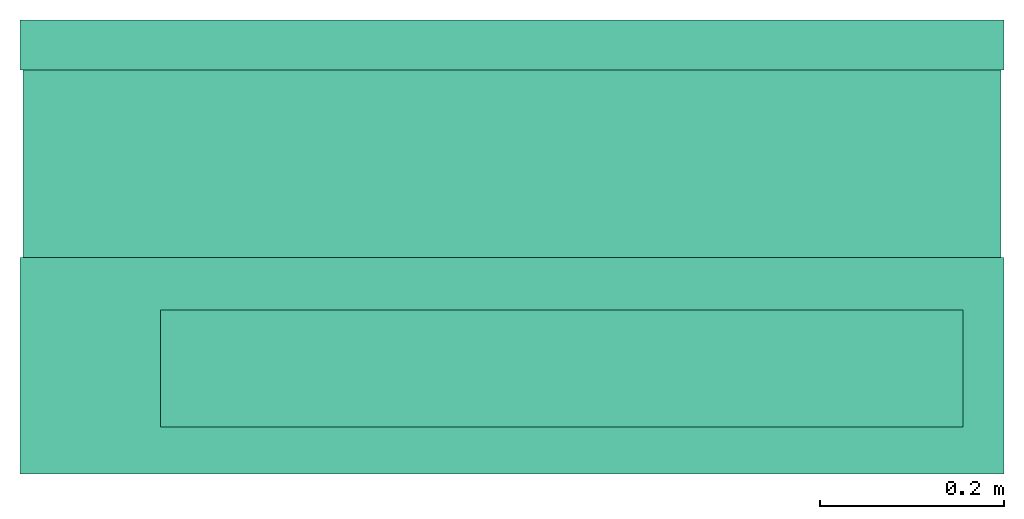
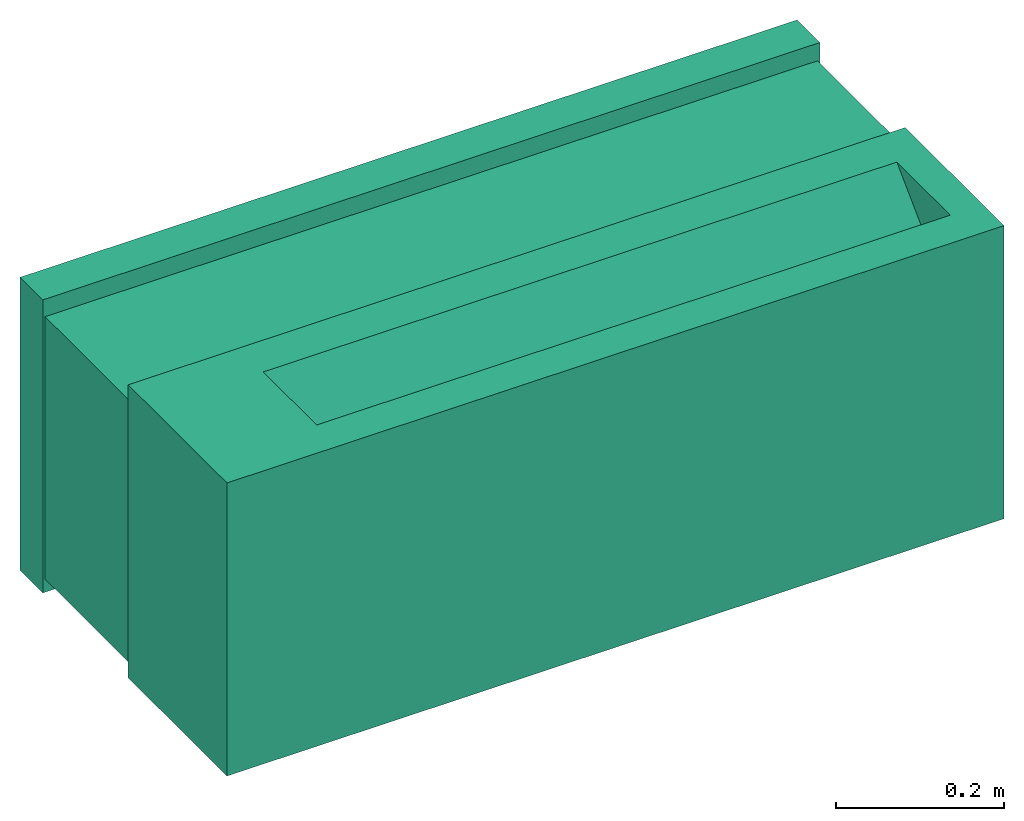
# One storey: 1 energy conversion device.
"""IFC2X3 building model written with IfcOpenShell, lengths in metres."""

import ifcopenshell
import ifcopenshell.guid

model = None  # the IFC model being written
_history = None  # IfcOwnerHistory: only IFC2X3 demands one
_inside = {}  # id of a spatial element -> (the spatial element, [elements in it])
_under = {}  # id of a project, library or spatial element -> (it, [spatial elements below it])
_declared = {}  # id of a project -> (the project, [libraries it declares])
_typed = {}  # id of a type object -> (the type object, [elements of that type])
_made_of = {}  # id of a material, layer set ... -> (it, [elements and type objects made of it])


def new_model(schema):
    """Start an empty IFC model of exactly this schema.

    Asked for "IFC4X3", IfcOpenShell would pick the latest addendum, in which some entities
    have other attributes; the version numbers below select the first issue.
    IFC2X3 requires an IfcOwnerHistory on every rooted entity: one is made here for all.
    """
    global model, _history
    if schema == "IFC4X3":
        model = ifcopenshell.file(schema_version=(4, 3, 0, 0))
    else:
        model = ifcopenshell.file(schema=schema)
    _inside.clear()
    _under.clear()
    _declared.clear()
    _typed.clear()
    _made_of.clear()
    _history = None
    if model.schema == "IFC2X3":
        org = make("IfcOrganization", Name="unknown")
        user = make(
            "IfcPersonAndOrganization",
            ThePerson=make("IfcPerson", FamilyName="unknown"),
            TheOrganization=org,
        )
        app = make(
            "IfcApplication",
            ApplicationDeveloper=org,
            Version="unknown",
            ApplicationFullName="unknown",
            ApplicationIdentifier="unknown",
        )
        _history = make(
            "IfcOwnerHistory",
            OwningUser=user,
            OwningApplication=app,
            ChangeAction="ADDED",
            CreationDate=0,
        )
    return model


def make(cls, **values):
    """One entity of the class cls with the attributes given. An attribute that is None is left unset."""
    return model.create_entity(
        cls, **{name: value for name, value in values.items() if value is not None}
    )


def entity(cls, *values):
    """Any entity or typed value of the class cls, its attributes in the order of the schema. None: left unset."""
    e = model.create_entity(cls)
    for i, value in enumerate(values):
        if value is not None:
            e[i] = value
    return e


def rooted(cls, **values):
    """An entity with a GlobalId (a new one), such as an element, a storey or a relation."""
    return make(cls, GlobalId=ifcopenshell.guid.new(), OwnerHistory=_history, **values)


def si_unit(unit_type, name, prefix=None):
    """IfcSIUnit, for example si_unit("LENGTHUNIT", "METRE", prefix="MILLI")."""
    return make("IfcSIUnit", UnitType=unit_type, Prefix=prefix, Name=name)


def converted_unit(unit_type, name, factor, base, dimensions=None, offset=None):
    """IfcConversionBasedUnit, such as the inch: factor (a typed value) times the base unit."""
    return make(
        "IfcConversionBasedUnit"
        if offset is None
        else "IfcConversionBasedUnitWithOffset",
        ConversionOffset=offset,
        Dimensions=None
        if dimensions is None
        else entity("IfcDimensionalExponents", *dimensions),
        UnitType=unit_type,
        Name=name,
        ConversionFactor=make(
            "IfcMeasureWithUnit", ValueComponent=factor, UnitComponent=base
        ),
    )


def assignment(units):
    """IfcUnitAssignment: the units of a project."""
    return None if units is None else make("IfcUnitAssignment", Units=units)


def point(xyz):
    """IfcCartesianPoint."""
    return None if xyz is None else make("IfcCartesianPoint", Coordinates=xyz)


def direction(xyz):
    """IfcDirection."""
    return None if xyz is None else make("IfcDirection", DirectionRatios=xyz)


def frame(location, z_axis=None, x_axis=None):
    """IfcAxis2Placement3D, a coordinate frame: its origin and axes. An axis left out is left unset."""
    return make(
        "IfcAxis2Placement3D",
        Location=point(location),
        Axis=direction(z_axis),
        RefDirection=direction(x_axis),
    )


def origin():
    """The frame at (0, 0, 0) with its axes left unset."""
    return frame((0.0, 0.0, 0.0))


def origin_with_axes():
    """The frame at (0, 0, 0) with the z axis (0, 0, 1) and the x axis (1, 0, 0) written out."""
    return frame((0.0, 0.0, 0.0), z_axis=(0.0, 0.0, 1.0), x_axis=(1.0, 0.0, 0.0))


def place(relative_to, where):
    """IfcLocalPlacement: puts the frame where relative to a parent placement (None: the world)."""
    return make(
        "IfcLocalPlacement", PlacementRelTo=relative_to, RelativePlacement=where
    )


def context(
    kind, dimensions, precision=None, world=None, true_north=None, identifier=None
):
    """IfcGeometricRepresentationContext, for example the 3D "Model" context."""
    return make(
        "IfcGeometricRepresentationContext",
        ContextIdentifier=identifier,
        ContextType=kind,
        CoordinateSpaceDimension=dimensions,
        Precision=precision,
        WorldCoordinateSystem=world,
        TrueNorth=true_north,
    )


def subcontext(parent, identifier, kind, view, scale=None):
    """IfcGeometricRepresentationSubContext, for example "Body" below "Model"."""
    return make(
        "IfcGeometricRepresentationSubContext",
        ContextIdentifier=identifier,
        ContextType=kind,
        ParentContext=parent,
        TargetScale=scale,
        TargetView=view,
    )


def project(units=None, contexts=None):
    """IfcProject with its units and contexts."""
    return rooted(
        "IfcProject",
        Name="project",
        RepresentationContexts=contexts,
        UnitsInContext=assignment(units),
    )


def spatial(cls, under=None, at=None, **own):
    """A site, building, storey or space (cls), placed at a placement, below another one or the project."""
    s = rooted(cls, ObjectPlacement=at, **own)
    if under is not None:
        _under.setdefault(under.id(), (under, []))[1].append(s)
    return s


def faces_of(points, faces, orient=None, outer=None):
    """IfcFace entities. A face is a list of loops; a loop is a list of indices into points, from 0.

    orient and outer hold one flag for each loop. By default every Orientation is true, the
    first loop of a face is its IfcFaceOuterBound and the others are IfcFaceBound.
    """
    made = []
    for i, loops in enumerate(faces):
        bounds = []
        for j, loop in enumerate(loops):
            is_outer = j == 0 if outer is None else outer[i][j]
            bounds.append(
                make(
                    "IfcFaceOuterBound" if is_outer else "IfcFaceBound",
                    Bound=make("IfcPolyLoop", Polygon=[points[k] for k in loop]),
                    Orientation=True if orient is None else orient[i][j],
                )
            )
        made.append(make("IfcFace", Bounds=bounds))
    return made


def open_shell(faces, orient=None, outer=None):
    """The faces of one IfcOpenShell. surface_model builds it on its shared points."""
    return ("IfcOpenShell", faces, orient, outer)


def faceted_brep(points, faces, orient=None, outer=None, voids=None):
    """IfcFacetedBrep: a solid bounded by flat faces; with voids (closed shells), ...WithVoids."""
    shared = [point(p) for p in points]
    hull = make("IfcClosedShell", CfsFaces=faces_of(shared, faces, orient, outer))
    if voids is None:
        return make("IfcFacetedBrep", Outer=hull)
    return make(
        "IfcFacetedBrepWithVoids",
        Outer=hull,
        Voids=[
            make(cls, CfsFaces=faces_of(shared, fs, o, b)) for cls, fs, o, b in voids
        ],
    )


def surface_model(cls, points, shells):
    """IfcFaceBasedSurfaceModel or IfcShellBasedSurfaceModel (cls): surfaces that need not close."""
    shared = [point(p) for p in points]
    made = [make(c, CfsFaces=faces_of(shared, fs, o, b)) for c, fs, o, b in shells]
    if cls == "IfcFaceBasedSurfaceModel":
        return make(cls, FbsmFaces=made)
    return make(cls, SbsmBoundary=made)


def shape(context_of_items, identifier, shape_type, items):
    """IfcShapeRepresentation: the items that make up one representation, for example the "Body"."""
    return make(
        "IfcShapeRepresentation",
        ContextOfItems=context_of_items,
        RepresentationIdentifier=identifier,
        RepresentationType=shape_type,
        Items=items,
    )


def made_of(thing, what):
    """Note that an element or type object is made of a material, layer set ...; save() writes the relation."""
    if what is not None:
        _made_of.setdefault(what.id(), (what, []))[1].append(thing)
    return thing


def type_object(cls, material=None, **own):
    """A type object (cls), such as IfcWallType, which elements share."""
    return made_of(rooted(cls, **own), material)


def element(
    cls,
    number,
    at=None,
    inside=None,
    cuts=None,
    type_object=None,
    material=None,
    context=None,
    identifier="Body",
    shape_type=None,
    held_by="IfcProductDefinitionShape",
    body=None,
    shapes=None,
    **own,
):
    """One element of the class cls, such as IfcWall. Its Tag is "e" and its number.

    at: its placement. inside: the storey or other place that contains it. cuts: it is an
    opening in that element (IfcRelVoidsElement). A single representation is given by context,
    identifier, shape_type and body (its items); several are given by shapes. held_by: the class
    of the entity that holds the representations. save() writes the other relations.
    """
    e = rooted(cls, Tag="e%d" % number, ObjectPlacement=at, **own)
    if body is not None:
        shapes = [shape(context, identifier, shape_type, body)]
    if shapes is not None:
        e.Representation = make(held_by, Representations=shapes)
    if inside is not None:
        _inside.setdefault(inside.id(), (inside, []))[1].append(e)
    if cuts is not None:
        rooted(
            "IfcRelVoidsElement", RelatingBuildingElement=cuts, RelatedOpeningElement=e
        )
    if type_object is not None:
        _typed.setdefault(type_object.id(), (type_object, []))[1].append(e)
    return made_of(e, material)


def aggregate(whole, parts):
    """IfcRelAggregates: a whole, such as a stair, and the parts it consists of."""
    return rooted("IfcRelAggregates", RelatingObject=whole, RelatedObjects=parts)


def save(model, path):
    """Write the relations noted so far, then the file.

    IfcRelAggregates (storeys below a building ...), IfcRelContainedInSpatialStructure (elements
    in a storey), IfcRelDefinesByType, IfcRelAssociatesMaterial and IfcRelDeclares: one each for
    every whole, place, type object, material and project.
    """
    for whole, parts in _under.values():
        aggregate(whole, parts)
    for where, things in _inside.values():
        rooted(
            "IfcRelContainedInSpatialStructure",
            RelatedElements=things,
            RelatingStructure=where,
        )
    for kind, things in _typed.values():
        rooted("IfcRelDefinesByType", RelatedObjects=things, RelatingType=kind)
    for what, things in _made_of.values():
        rooted("IfcRelAssociatesMaterial", RelatedObjects=things, RelatingMaterial=what)
    for by, libraries in _declared.values():
        rooted("IfcRelDeclares", RelatingContext=by, RelatedDefinitions=libraries)
    model.write(path)


model = new_model("IFC2X3")

# Units and contexts
model_context = context("Model", 3, precision=1e-05, world=origin())
body_context = subcontext(model_context, "Body", "Model", "MODEL_VIEW")
ifc_project = project(units=[si_unit("LENGTHUNIT", "METRE"), si_unit("AREAUNIT", "SQUARE_METRE"), si_unit("VOLUMEUNIT", "CUBIC_METRE"), converted_unit("PLANEANGLEUNIT", "DEGREE", entity("IfcPlaneAngleMeasure", 0.0174532925199433), si_unit("PLANEANGLEUNIT", "RADIAN"), dimensions=[0, 0, 0, 0, 0, 0, 0]), si_unit("SOLIDANGLEUNIT", "STERADIAN"), si_unit("MASSUNIT", "GRAM"), si_unit("TIMEUNIT", "SECOND"), si_unit("THERMODYNAMICTEMPERATUREUNIT", "DEGREE_CELSIUS"), si_unit("LUMINOUSINTENSITYUNIT", "LUMEN")], contexts=[model_context])

# Site, building, storey
site_placement = place(None, origin_with_axes())
site = spatial("IfcSite", under=ifc_project, at=site_placement, CompositionType="ELEMENT")
building_placement = place(site_placement, origin_with_axes())
building = spatial("IfcBuilding", under=site, at=building_placement, CompositionType="ELEMENT")
storey_placement = place(building_placement, origin_with_axes())
storey = spatial("IfcBuildingStorey", under=building, at=storey_placement, CompositionType="ELEMENT", Elevation=0.0)

# Energy conversion device
heat_exchanger_type = type_object("IfcHeatExchangerType", PredefinedType="NOTDEFINED")
energy_conversion_device_placement = place(storey_placement, origin_with_axes())
element("IfcEnergyConversionDevice", 1, at=energy_conversion_device_placement, inside=storey, type_object=heat_exchanger_type, context=body_context, shape_type="SurfaceModel", body=[
    faceted_brep([(-0.5334, 0.257302002906799, 0.0), (-0.5334, 0.2032, 0.0), (-0.5334, 0.2032, 0.42545), (-0.5334, 0.257302002906799, 0.42545), (0.5334, 0.2032, 0.42545), (0.5334, 0.257302002906799, 0.42545), (0.5334, 0.2032, 0.0), (0.5334, 0.257302002906799, 0.0), (-0.508, 0.2032, 0.40005), (-0.508, 0.2032, 0.0254), (0.508, 0.2032, 0.40005), (0.508, 0.2032, 0.0254), (-0.508, 0.257302002906799, 0.40005), (-0.508, 0.257302002906799, 0.0254), (0.508, 0.257302002906799, 0.40005), (0.508, 0.257302002906799, 0.0254)], [[[0, 1, 2]], [[2, 3, 0]], [[3, 2, 4]], [[4, 5, 3]], [[5, 4, 6]], [[6, 7, 5]], [[7, 6, 1]], [[1, 0, 7]], [[8, 2, 1]], [[1, 9, 8]], [[2, 8, 10]], [[10, 4, 2]], [[9, 1, 6]], [[6, 11, 9]], [[11, 6, 4]], [[4, 10, 11]], [[12, 13, 0]], [[0, 3, 12]], [[3, 5, 14]], [[14, 12, 3]], [[13, 15, 7]], [[7, 0, 13]], [[15, 14, 5]], [[5, 7, 15]], [[13, 12, 8]], [[8, 9, 13]], [[12, 14, 10]], [[10, 8, 12]], [[14, 15, 11]], [[11, 10, 14]], [[15, 13, 9]], [[9, 11, 15]]]),
    surface_model("IfcShellBasedSurfaceModel", [(-0.508, 0.2032, 0.40005), (0.508, 0.2032, 0.40005), (0.508, 0.257302002906799, 0.40005), (-0.508, 0.257302002906799, 0.40005), (0.508, 0.230948984527588, 0.384047997093201), (-0.508, 0.230948984527588, 0.384047997093201), (-0.508, 0.2032, 0.384047997093201), (0.508, 0.2032, 0.384047997093201), (0.508, 0.226547387886047, 0.384047997093201), (-0.508, 0.226547387886047, 0.384047997093201), (0.508, 0.2563631067276, 0.358902002906799), (0.508, 0.254028244400024, 0.356567140579223), (-0.508, 0.254028244400024, 0.356567140579223), (-0.508, 0.2563631067276, 0.358902002906799), (-0.508, 0.2563631067276, 0.30860999031067), (-0.508, 0.254028244400024, 0.306275127983093), (-0.508, 0.2032, 0.357103396606444), (-0.508, 0.205534862327576, 0.359438234710693), (0.508, 0.2032, 0.357103396606444), (0.508, 0.205534862327576, 0.359438234710693), (0.508, 0.254028244400024, 0.306275127983093), (0.508, 0.2563631067276, 0.30860999031067), (-0.508, 0.2563631067276, 0.258318001937865), (-0.508, 0.254028244400024, 0.255983139610291), (-0.508, 0.2032, 0.306811384010315), (-0.508, 0.205534862327576, 0.309146246337891), (0.508, 0.2032, 0.306811384010315), (0.508, 0.205534862327576, 0.309146246337891), (0.508, 0.254028244400024, 0.255983139610291), (0.508, 0.2563631067276, 0.258318001937865), (-0.508, 0.2563631067276, 0.208025989341736), (-0.508, 0.254028244400024, 0.20569112701416), (-0.508, 0.2032, 0.256519371414183), (-0.508, 0.205534862327576, 0.258854257965087), (0.508, 0.2032, 0.256519371414183), (0.508, 0.205534862327576, 0.258854257965087), (0.508, 0.254028244400024, 0.20569112701416), (0.508, 0.2563631067276, 0.208025989341736), (-0.508, 0.2563631067276, 0.157734000968933), (-0.508, 0.254028244400024, 0.155399138641357), (-0.508, 0.2032, 0.206227383041382), (-0.508, 0.205534862327576, 0.208562245368957), (0.508, 0.2032, 0.206227383041382), (0.508, 0.205534862327576, 0.208562245368957), (0.508, 0.254028244400024, 0.155399138641357), (0.508, 0.2563631067276, 0.157734000968933), (-0.508, 0.2563631067276, 0.107442000484467), (-0.508, 0.254028244400024, 0.105107138156891), (-0.508, 0.2032, 0.155935382556915), (-0.508, 0.205534862327576, 0.158270256996155), (0.508, 0.2032, 0.155935382556915), (0.508, 0.205534862327576, 0.158270256996155), (0.508, 0.254028244400024, 0.105107138156891), (0.508, 0.2563631067276, 0.107442000484467), (-0.508, 0.2563631067276, 0.05715), (-0.508, 0.254028244400024, 0.0548151376724244), (-0.508, 0.2032, 0.105643382072449), (-0.508, 0.205534862327576, 0.107978244400024), (0.508, 0.2032, 0.105643382072449), (0.508, 0.205534862327576, 0.107978244400024), (0.508, 0.254028244400024, 0.0548151376724244), (0.508, 0.2563631067276, 0.05715)], [open_shell([[[0, 1, 2]], [[2, 3, 0]], [[3, 2, 4]], [[4, 5, 3]], [[6, 7, 1]], [[1, 0, 6]], [[1, 4, 2]], [[1, 7, 8]], [[4, 1, 8]], [[0, 3, 5]], [[5, 9, 0]], [[9, 6, 0]], [[10, 4, 8]], [[8, 11, 10]], [[10, 11, 12]], [[12, 13, 10]], [[8, 9, 12]], [[12, 11, 8]], [[5, 13, 12]], [[12, 9, 5]], [[4, 10, 13]], [[13, 5, 4]], [[9, 8, 7]], [[7, 6, 9]], [[14, 15, 16]], [[16, 17, 14]], [[17, 16, 18]], [[18, 19, 17]], [[19, 18, 20]], [[20, 21, 19]], [[21, 20, 15]], [[15, 14, 21]], [[18, 16, 15]], [[15, 20, 18]], [[19, 21, 14]], [[14, 17, 19]], [[22, 23, 24]], [[24, 25, 22]], [[25, 24, 26]], [[26, 27, 25]], [[27, 26, 28]], [[28, 29, 27]], [[29, 28, 23]], [[23, 22, 29]], [[26, 24, 23]], [[23, 28, 26]], [[27, 29, 22]], [[22, 25, 27]], [[30, 31, 32]], [[32, 33, 30]], [[33, 32, 34]], [[34, 35, 33]], [[35, 34, 36]], [[36, 37, 35]], [[37, 36, 31]], [[31, 30, 37]], [[34, 32, 31]], [[31, 36, 34]], [[35, 37, 30]], [[30, 33, 35]], [[38, 39, 40]], [[40, 41, 38]], [[41, 40, 42]], [[42, 43, 41]], [[43, 42, 44]], [[44, 45, 43]], [[45, 44, 39]], [[39, 38, 45]], [[42, 40, 39]], [[39, 44, 42]], [[43, 45, 38]], [[38, 41, 43]], [[46, 47, 48]], [[48, 49, 46]], [[49, 48, 50]], [[50, 51, 49]], [[51, 50, 52]], [[52, 53, 51]], [[53, 52, 47]], [[47, 46, 53]], [[50, 48, 47]], [[47, 52, 50]], [[51, 53, 46]], [[46, 49, 51]], [[54, 55, 56]], [[56, 57, 54]], [[57, 56, 58]], [[58, 59, 57]], [[59, 58, 60]], [[60, 61, 59]], [[61, 60, 55]], [[55, 54, 61]], [[58, 56, 55]], [[55, 60, 58]], [[59, 61, 54]], [[54, 57, 59]]])]),
    faceted_brep([(0.5334, -0.23495, 0.42545), (0.48895, -0.18415, 0.42545), (-0.381, -0.18415, 0.42545), (-0.5334, -0.23495, 0.42545), (-0.381, -0.05715, 0.42545), (-0.5334, -2.81996648254791e-18, 0.42545), (0.5334, -2.81996648254791e-18, 0.42545), (0.48895, -0.05715, 0.42545), (-0.5334, -2.81996648254791e-18, 0.0), (-0.5334, -0.23495, 0.0), (0.5334, -2.81996648254791e-18, 0.0), (0.5334, -0.23495, 0.0), (-0.381, -0.18415, 0.300256769561767), (0.48895, -0.18415, 0.300256769561767)], [[[0, 1, 2]], [[2, 3, 0]], [[4, 5, 3]], [[3, 2, 4]], [[1, 0, 6]], [[6, 7, 1]], [[5, 4, 7]], [[7, 6, 5]], [[3, 5, 8]], [[8, 9, 3]], [[10, 11, 9]], [[9, 8, 10]], [[6, 0, 11]], [[11, 10, 6]], [[0, 3, 9]], [[9, 11, 0]], [[6, 10, 8]], [[8, 5, 6]], [[7, 4, 12]], [[12, 13, 7]], [[13, 12, 2]], [[2, 1, 13]], [[1, 7, 13]], [[2, 12, 4]]]),
    faceted_brep([(-0.530225, 0.0, 0.01905), (0.530225, 0.0, 0.01905), (0.530225, 0.0, 0.40005), (-0.530225, 0.0, 0.40005), (0.530225, 0.2032, 0.01905), (0.530225, 0.2032, 0.40005), (-0.530225, 0.2032, 0.01905), (-0.530225, 0.2032, 0.40005)], [[[0, 1, 2]], [[2, 3, 0]], [[1, 4, 5]], [[5, 2, 1]], [[4, 6, 7]], [[7, 5, 4]], [[6, 0, 3]], [[3, 7, 6]], [[1, 0, 6]], [[6, 4, 1]], [[2, 7, 3]], [[7, 2, 5]]]),
])

save(model, "model.ifc")
